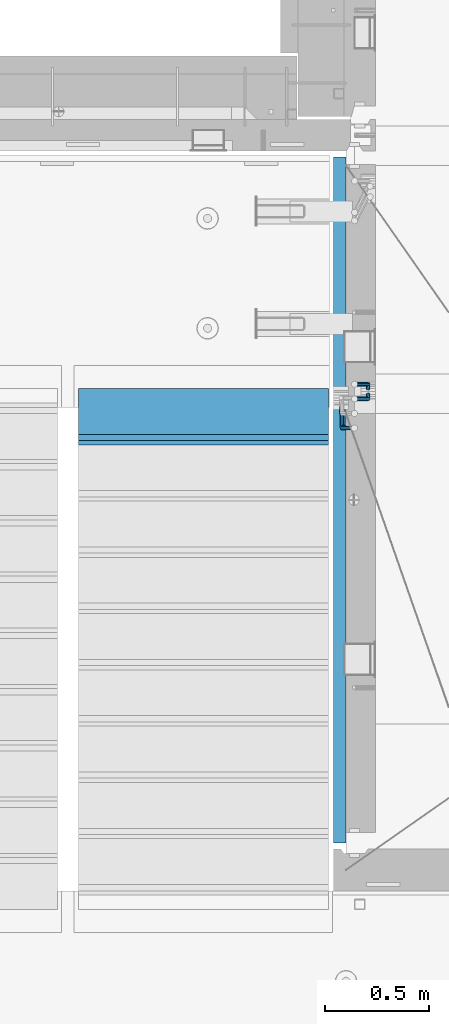
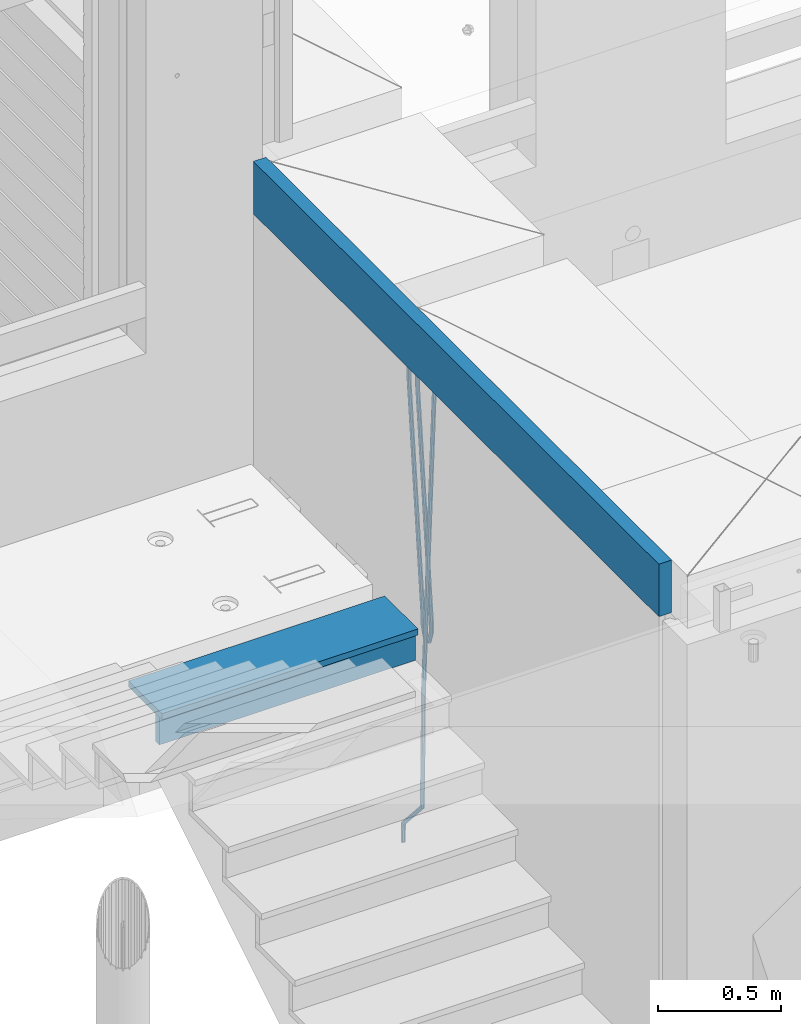
# One storey, part 104 of 325: 6 beams, 2 elements without a shape of their own.
"""IFC2X3 building model written with IfcOpenShell, lengths in millimetres."""

from ifc_helpers import new_model, si_unit, frame, origin_with_axes, place, context, subcontext, project, spatial, faceted_brep, material, type_object, element, aggregate, save


model = new_model("IFC2X3")

# Units and contexts
model_context = context("Model", 3, precision=1e-05, world=origin_with_axes())
body_context = subcontext(model_context, "Body", "Model", "MODEL_VIEW")
ifc_project = project(units=[si_unit("LENGTHUNIT", "METRE", prefix="MILLI"), si_unit("AREAUNIT", "SQUARE_METRE"), si_unit("VOLUMEUNIT", "CUBIC_METRE"), si_unit("MASSUNIT", "GRAM", prefix="KILO"), si_unit("TIMEUNIT", "SECOND"), si_unit("PLANEANGLEUNIT", "RADIAN"), si_unit("SOLIDANGLEUNIT", "STERADIAN"), si_unit("THERMODYNAMICTEMPERATUREUNIT", "DEGREE_CELSIUS"), si_unit("LUMINOUSINTENSITYUNIT", "LUMEN")], contexts=[model_context])

# Site, building, storey
site_placement = place(None, origin_with_axes())
site = spatial("IfcSite", under=ifc_project, at=site_placement, CompositionType="ELEMENT")
building_placement = place(site_placement, origin_with_axes())
building = spatial("IfcBuilding", under=site, at=building_placement, CompositionType="ELEMENT")
storey_placement = place(building_placement, origin_with_axes())
storey = spatial("IfcBuildingStorey", under=building, at=storey_placement, Name="1", CompositionType="ELEMENT", Elevation=0.0)

# Assembly, beams
assembly_1_placement = place(storey_placement, origin_with_axes())
assembly_1 = element("IfcElementAssembly", 1, at=assembly_1_placement, inside=storey, AssemblyPlace="NOTDEFINED", PredefinedType="REINFORCEMENT_UNIT")
ifc_material_1 = material()
beam_type_1 = type_object("IfcBeamType", Name="D20", PredefinedType="NOTDEFINED")
beam_1_placement = place(assembly_1_placement, frame((22244.9999977209, 19244.9999999961, 82050.0), z_axis=(0.999839490204639, 0.000205763000043867, -0.0179151190036643), x_axis=(0.0179151190067552, -2.89999975377855e-08, 0.999839511377188)))
beam_1 = element("IfcBeam", 2, at=beam_1_placement, type_object=beam_type_1, material=ifc_material_1, Name="JM20", ObjectType="D20", context=body_context, shape_type="Brep", body=[
    faceted_brep([(0.0, -10.0, 0.0), (-4.19531716033816e-08, -7.07106781186667, -7.07106781187031), (86.7315929719771, -7.07106781168841, -7.07106781093171), (86.731592974611, -9.99999999982174, 9.31322574615479e-10), (0.0, 0.0, -10.0), (86.7315929708711, 1.78260961547494e-10, -9.99999999906868), (4.196772351861e-08, 7.07106781186303, -7.07106781186667), (86.7315929719334, 7.07106781204129, -7.07106781093171), (0.0, 10.0, 0.0), (86.7315929745673, 10.0000000001783, 9.27684595808387e-10), (4.196772351861e-08, 7.07106781185939, 7.07106781185939), (86.7315929772012, 7.07106781204129, 7.07106781279799), (0.0, 0.0, 10.0), (86.7315929782926, 1.74622982740402e-10, 10.0000000009313), (-4.19531716033816e-08, -7.07106781187031, 7.07106781185939), (86.7315929772303, -7.07106781168841, 7.07106781279799), (93.6677956489439, -7.07106781167022, -7.07106781085895), (94.7376134546503, -9.99999999980355, 1.01863406598568e-09), (91.026200105669, 1.81898940354586e-10, -9.99999999902138), (88.3602376677445, 7.07106781204493, -7.07106781091352), (87.2315929745673, 10.0000000001783, 9.3496055342257e-10), (88.3014107802737, 7.07106781204129, 7.07106781281254), (90.9430063235777, 1.89174897968769e-10, 10.000000000975), (93.6089687614876, -7.07106781167386, 7.07106781287075), (98.8911095756193, -2.50758877894623, -7.02048799755357), (100.766554680595, -4.73266449970106, 0.0583810835851182), (94.2602580335224, 2.82551570757641, -9.96868309015917), (89.5866900823166, 8.14258868119578, -7.05919149349938), (87.6081184431823, 10.3289609061103, 0.00364607471055933), (89.4835635481722, 8.10388518535547, 7.08251515584925), (94.1144150902546, 2.7707806988401, 10.0307102484549), (98.7879830414458, -2.54629227479018, 7.12121865179506), (258.451659159182, 136.896481644191, -5.47538790942781), (260.327104264172, 134.671405923429, 1.60348117171452), (253.82080761707, 142.229586130707, -8.42358300202977), (249.147239665865, 147.546659104333, -5.51409140536998), (247.16866802673, 149.733031329244, 1.54874616283632), (249.044113131706, 147.507955608489, 8.62761524397865), (253.674964673817, 142.174851121974, 11.5758103365806), (258.348532625008, 136.857778148344, 8.66631873992083), (259.609028572653, 137.907646419204, -5.46418055530739), (260.703629732772, 135.000366829368, 1.60712724548284), (256.957140256956, 144.969721692669, -8.39321241324069), (254.301404995116, 152.04972473306, -5.46418119056762), (253.197516485467, 155.000285780967, 1.60712634709125), (254.2921176456, 152.093006191128, 8.67843414788877), (256.944005961297, 145.03093091767, 11.6074660058221), (259.599741223123, 137.950927877275, 8.67843478314535), (261.145884681828, 137.907643836123, -5.47671314841864), (261.203613108824, 135.000365989017, 1.60305003345638), (261.121836439444, 144.969714692827, -8.42717424114744), (261.145555515963, 152.049713229706, -5.51999315186185), (261.203147597975, 155.000272325447, 1.54184286560849), (261.260876025, 152.092994478338, 8.62160604748351), (261.284924267369, 145.030923621638, 11.5720671402123), (261.261205190865, 137.950925084755, 8.66488605092309), (839.157665647057, 137.906672338933, -10.1902230354935), (839.215394074068, 134.999394491828, -3.11045985361488), (839.133617404688, 144.968743195634, -13.140684128226), (839.157336481163, 152.048741732513, -10.2335030389368), (839.214928563219, 154.999300828251, -3.17166702147006), (839.272656990215, 152.092022981145, 3.9080961604086), (839.296705232598, 145.029952124449, 6.85855725313741), (839.272986156095, 137.949953587562, 3.95137616384818), (839.868781161887, 137.906671143719, -10.1960219657631), (839.838848779618, 134.999393443952, -3.11554393670303), (839.881250229548, 144.968741939047, -13.1467808460184), (839.868951771874, 152.048740536462, -10.2393060447248), (839.83909005858, 154.999299779189, -3.17675686821167), (839.809157676311, 152.092022079421, 3.90372116084836), (839.796688608665, 145.029951284097, 6.85448004110731), (839.808987066324, 137.949952686675, 3.9470052398101), (840.579822222964, 137.906673584588, -10.1842104245625), (840.462238209511, 134.999395583931, -3.10518843076352), (840.628804777298, 144.968744505262, -13.1343627568021), (840.580492556488, 152.048742979052, -10.2274862023114), (840.463186204273, 154.999301921594, -3.16638962257639), (840.345602190806, 152.092023920934, 3.91263237122257), (840.296619636472, 145.02995300027, 6.8627847034586), (840.344931857282, 137.949954526477, 3.9559081489715), (2234.26962238546, 137.911457860533, 12.9672296118515), (2234.15203837199, 135.004179859876, 20.0462516056541), (2234.31860493978, 144.973528781204, 10.0170772796155), (2234.27029271898, 152.053527254993, 12.9239538341062), (2234.15298636674, 155.004086197539, 19.9850504138449), (2234.03540235329, 152.096808196879, 27.0640724076402), (2233.98641979897, 145.034737276212, 30.0142247398726), (2234.03473201978, 137.954738802422, 27.1073481853855), (2234.80822680684, 137.911459709463, 12.9761767017735), (2234.65218745513, 135.004181576795, 20.0545598902536), (2234.91137536684, 144.973530816071, 10.0269241544374), (2234.90121010756, 152.053529420817, 12.9344343916055), (2234.78368570004, 155.004088362613, 19.9955273490887), (2234.62764634831, 152.096810229945, 27.0739105375687), (2234.52449778831, 145.03473912333, 30.0231630849084), (2234.5346630476, 137.954740518591, 27.1156528477368), (2235.34672799108, 137.904437526307, 12.9880904207748), (2235.15224067199, 134.997660764246, 20.0656229922242), (2235.50403217443, 144.965802430743, 10.0400360042804), (2235.53200656486, 152.045303685409, 12.9483900373125), (2235.41426414385, 154.995865470151, 20.0094781715015), (2235.21977682479, 152.089088708097, 27.0870107429473), (2235.06247264144, 145.027723803654, 30.0350651594381), (2235.03449825099, 137.948222548996, 27.1267111264096), (2257.18426469299, 137.619670868506, 13.471220789932), (2256.98977737389, 134.712894106447, 20.5487533613814), (2257.34156887633, 144.681035772945, 10.5231663734412), (2257.36954326676, 151.760537027607, 13.431520406466), (2257.25180084576, 154.711098812357, 20.4926085406587), (2257.05731352669, 151.804322050295, 27.5701411121045), (2256.90000934334, 144.742957145856, 30.5181955285952), (2256.87203495289, 137.663455891194, 27.6098414955668), (2257.81978538656, 137.611383527939, 13.4852809539261), (2257.64977173437, 134.704287623455, 20.5633549770937), (2257.92004271412, 144.673492336904, 10.5359644413984), (2257.89181433429, 151.75372648902, 13.443075052819), (2257.75163604916, 154.704580842757, 20.5036668193279), (2257.58162239699, 151.797484938277, 27.5817408424919), (2257.48136506943, 144.735376129309, 30.5310573550196), (2257.50959344923, 137.655141977193, 27.6239467436062), (2258.45536166341, 137.613263996915, 13.4991438851757), (2258.30982363551, 134.706257484584, 20.5777578442503), (2258.49856749365, 144.67519573247, 10.5485681479549), (2258.41413173683, 151.755268857134, 13.4544378826395), (2258.25151571419, 154.706072557059, 20.5145340091476), (2258.1059776863, 151.799066044725, 27.5931479682222), (2258.06277185606, 144.737134309165, 30.5437237054466), (2258.14720761286, 137.657061184509, 27.6378539707584), (2358.46082715187, 137.911709587963, 15.6778446678582), (2358.31528912397, 135.004703075636, 22.7564586269327), (2358.50403298211, 144.973641323526, 12.7272689306337), (2358.41959722531, 152.053714448179, 15.6331386653219), (2358.25698120265, 155.004518148104, 22.69323479183), (2358.11144317476, 152.097511635777, 29.7718487509119), (2358.06823734453, 145.035579900217, 32.722424488129), (2358.15267310133, 137.955506775557, 29.8165547534445)], [[[0, 1, 2, 3]], [[1, 4, 5, 2]], [[4, 6, 7, 5]], [[6, 8, 9, 7]], [[8, 10, 11, 9]], [[10, 12, 13, 11]], [[12, 14, 15, 13]], [[14, 0, 3, 15]], [[14, 12, 10, 8, 6, 4, 1, 0]], [[3, 2, 16, 17]], [[2, 5, 18, 16]], [[5, 7, 19, 18]], [[7, 9, 20, 19]], [[9, 11, 21, 20]], [[11, 13, 22, 21]], [[13, 15, 23, 22]], [[15, 3, 17, 23]], [[17, 16, 24, 25]], [[16, 18, 26, 24]], [[18, 19, 27, 26]], [[19, 20, 28, 27]], [[20, 21, 29, 28]], [[21, 22, 30, 29]], [[22, 23, 31, 30]], [[23, 17, 25, 31]], [[25, 24, 32, 33]], [[24, 26, 34, 32]], [[26, 27, 35, 34]], [[27, 28, 36, 35]], [[28, 29, 37, 36]], [[29, 30, 38, 37]], [[30, 31, 39, 38]], [[31, 25, 33, 39]], [[33, 32, 40, 41]], [[32, 34, 42, 40]], [[34, 35, 43, 42]], [[35, 36, 44, 43]], [[36, 37, 45, 44]], [[37, 38, 46, 45]], [[38, 39, 47, 46]], [[39, 33, 41, 47]], [[41, 40, 48, 49]], [[40, 42, 50, 48]], [[42, 43, 51, 50]], [[43, 44, 52, 51]], [[44, 45, 53, 52]], [[45, 46, 54, 53]], [[46, 47, 55, 54]], [[47, 41, 49, 55]], [[49, 48, 56, 57]], [[48, 50, 58, 56]], [[50, 51, 59, 58]], [[51, 52, 60, 59]], [[52, 53, 61, 60]], [[53, 54, 62, 61]], [[54, 55, 63, 62]], [[55, 49, 57, 63]], [[57, 56, 64, 65]], [[56, 58, 66, 64]], [[58, 59, 67, 66]], [[59, 60, 68, 67]], [[60, 61, 69, 68]], [[61, 62, 70, 69]], [[62, 63, 71, 70]], [[63, 57, 65, 71]], [[65, 64, 72, 73]], [[64, 66, 74, 72]], [[66, 67, 75, 74]], [[67, 68, 76, 75]], [[68, 69, 77, 76]], [[69, 70, 78, 77]], [[70, 71, 79, 78]], [[71, 65, 73, 79]], [[73, 72, 80, 81]], [[72, 74, 82, 80]], [[74, 75, 83, 82]], [[75, 76, 84, 83]], [[76, 77, 85, 84]], [[77, 78, 86, 85]], [[78, 79, 87, 86]], [[79, 73, 81, 87]], [[81, 80, 88, 89]], [[80, 82, 90, 88]], [[82, 83, 91, 90]], [[83, 84, 92, 91]], [[84, 85, 93, 92]], [[85, 86, 94, 93]], [[86, 87, 95, 94]], [[87, 81, 89, 95]], [[89, 88, 96, 97]], [[88, 90, 98, 96]], [[90, 91, 99, 98]], [[91, 92, 100, 99]], [[92, 93, 101, 100]], [[93, 94, 102, 101]], [[94, 95, 103, 102]], [[95, 89, 97, 103]], [[97, 96, 104, 105]], [[96, 98, 106, 104]], [[98, 99, 107, 106]], [[99, 100, 108, 107]], [[100, 101, 109, 108]], [[101, 102, 110, 109]], [[102, 103, 111, 110]], [[103, 97, 105, 111]], [[105, 104, 112, 113]], [[104, 106, 114, 112]], [[106, 107, 115, 114]], [[107, 108, 116, 115]], [[108, 109, 117, 116]], [[109, 110, 118, 117]], [[110, 111, 119, 118]], [[111, 105, 113, 119]], [[113, 112, 120, 121]], [[112, 114, 122, 120]], [[114, 115, 123, 122]], [[115, 116, 124, 123]], [[116, 117, 125, 124]], [[117, 118, 126, 125]], [[118, 119, 127, 126]], [[119, 113, 121, 127]], [[121, 120, 128, 129]], [[120, 122, 130, 128]], [[122, 123, 131, 130]], [[123, 124, 132, 131]], [[124, 125, 133, 132]], [[125, 126, 134, 133]], [[126, 127, 135, 134]], [[127, 121, 129, 135]], [[130, 131, 132, 133, 134, 135, 129, 128]]]),
])
beam_2_placement = place(assembly_1_placement, frame((22375.0998642727, 19290.4651594444, 82985.0), z_axis=(-1.0, 3.00000001838171e-08, 0.0), x_axis=(0.0, 0.316227766016838, 0.948683298050514)))
beam_2 = element("IfcBeam", 3, at=beam_2_placement, type_object=beam_type_1, material=ifc_material_1, Name="JM20", ObjectType="D20", context=body_context, shape_type="Brep", body=[
    faceted_brep([(0.0, -10.0, 0.0), (-4.19531716033816e-08, -7.07106781186667, -7.07106781187031), (61.1227766014781, -7.07106781179846, -7.07106781186667), (61.1227766014781, -9.99999999993179, 0.0), (0.0, 0.0, -10.0), (61.1227766014781, 6.45741238258779e-11, -10.0), (4.196772351861e-08, 7.07106781186303, -7.07106781186667), (61.1227766014636, 7.07106781193124, -7.07106781186667), (0.0, 10.0, 0.0), (61.1227766014636, 10.0000000000682, 0.0), (4.196772351861e-08, 7.07106781185939, 7.07106781185939), (61.1227766014636, 7.07106781193124, 7.07106781186667), (0.0, 0.0, 10.0), (61.1227766014781, 6.45741238258779e-11, 10.0), (-4.19531716033816e-08, -7.07106781187031, 7.07106781185939), (61.1227766014781, -7.07106781179846, 7.07106781186667), (62.0980768637673, -7.0710678118021, -7.07106781186667), (61.6227766014781, -9.99999999993179, 0.0), (63.2455532031745, 6.45741238258779e-11, -10.0), (64.3930295425671, 7.07106781193852, -7.07106781186667), (64.8683298048418, 10.0000000000719, 0.0), (64.3930295425671, 7.07106781193852, 7.07106781186667), (63.2455532031745, 6.45741238258779e-11, 10.0), (62.0980768637673, -7.0710678118021, 7.07106781186667), (63.0233279331733, -7.37948483493619, -7.07106781186667), (62.0971182505018, -10.1581138829397, 0.0), (65.2593959106744, -0.671280902436592, -10.0), (67.4954638881754, 6.03692303006665, -7.07106781186667), (68.4216735708469, 8.81555207807014, 0.0), (67.4954638881754, 6.03692303006665, 7.07106781186667), (65.2593959106744, -0.671280902436592, 10.0), (63.0233279331733, -7.37948483493619, 7.07106781186667), (107.709464777348, -22.2748637829909, -7.07106781186667), (106.783255094677, -25.0534928309944, 0.0), (109.945532754849, -15.5666598504913, -10.0), (112.18160073235, -8.85845591798807, -7.07106781186667), (113.107810415022, -6.07982686998457, 0.0), (112.18160073235, -8.85845591798807, 7.07106781186667), (109.945532754849, -15.5666598504913, 10.0), (107.709464777348, -22.2748637829909, 7.07106781186667), (108.62738737154, -22.5808379810596, -7.07106781186667), (107.517440445372, -25.2982212812285, 0.0), (110.939561807201, -15.8980028679443, -10.0), (113.099523326542, -9.16443011605679, -7.07106781186667), (113.841995765717, -6.32455532021868, 0.0), (112.732048839549, -9.04193862038755, 7.07106781186667), (110.419874403873, -15.7247737334992, 10.0), (108.259912884547, -22.4583464853904, 7.07106781186667), (109.543933731853, -22.8863534344937, -7.01810390034007), (108.250525037933, -25.5425828120797, 0.0423623170463543), (111.932100519902, -16.2288491055087, -9.94264476425815), (114.016069686855, -9.46994556949085, -7.01810390034007), (114.575080358278, -6.56891685106984, 0.0423623170463543), (113.281671664372, -9.22514622866311, 7.10282853442914), (110.893504876323, -15.8826505576517, 10.0273693983472), (108.80953570937, -22.6415540936659, 7.10282853442914), (1234.64045484473, -397.918527138788, 57.997169939692), (1233.34704615081, -400.574756516381, 65.0576361570747), (1237.02862163277, -391.261022809803, 55.0726290757739), (1239.11259079973, -384.502119273789, 57.997169939692), (1239.67160147114, -381.601090555371, 65.0576361570747), (1238.37819277724, -384.257319932957, 72.1181023744612), (1235.9900259892, -390.914824261946, 75.0426432383792), (1233.90605682223, -397.673727797956, 72.1181023744612), (1235.19007766954, -398.10173474706, 58.0289306622544), (1234.08013074337, -400.819118047232, 65.0999984741211), (1237.50225210523, -391.418899633955, 55.0999984741211), (1239.66221362454, -384.685326882061, 58.0289306622544), (1240.4046860637, -381.845452086222, 65.0999984741211), (1239.29473913755, -384.562835386395, 72.1710662859878), (1236.98256470189, -391.24567049951, 75.0999984741211), (1234.82260318255, -397.979243251394, 72.1710662859878), (1235.74052577675, -398.285217449463, 58.0289306622581), (1234.81431609408, -401.063846497466, 65.0999984741211), (1237.97659375425, -391.577013516963, 55.0999984741211), (1240.21266173176, -384.86880958446, 58.0289306622544), (1241.13887141441, -382.090180536457, 65.0999984741211), (1240.21266173176, -384.86880958446, 72.1710662859841), (1237.97659375425, -391.57701351696, 75.0999984741211), (1235.74052577675, -398.285217449459, 72.1710662859878), (1353.59175268197, -437.568959751207, 58.0289306622581), (1352.6655429993, -440.347588799211, 65.0999984741211), (1355.82782065947, -430.860755818708, 55.0999984741211), (1358.06388863697, -424.152551886204, 58.0289306622544), (1358.99009831963, -421.373922838201, 65.0999984741211), (1358.06388863697, -424.152551886204, 72.1710662859841), (1355.82782065947, -430.860755818704, 75.0999984741211), (1353.59175268197, -437.568959751204, 72.1710662859878)], [[[0, 1, 2, 3]], [[1, 4, 5, 2]], [[4, 6, 7, 5]], [[6, 8, 9, 7]], [[8, 10, 11, 9]], [[10, 12, 13, 11]], [[12, 14, 15, 13]], [[14, 0, 3, 15]], [[14, 12, 10, 8, 6, 4, 1, 0]], [[3, 2, 16, 17]], [[2, 5, 18, 16]], [[5, 7, 19, 18]], [[7, 9, 20, 19]], [[9, 11, 21, 20]], [[11, 13, 22, 21]], [[13, 15, 23, 22]], [[15, 3, 17, 23]], [[17, 16, 24, 25]], [[16, 18, 26, 24]], [[18, 19, 27, 26]], [[19, 20, 28, 27]], [[20, 21, 29, 28]], [[21, 22, 30, 29]], [[22, 23, 31, 30]], [[23, 17, 25, 31]], [[25, 24, 32, 33]], [[24, 26, 34, 32]], [[26, 27, 35, 34]], [[27, 28, 36, 35]], [[28, 29, 37, 36]], [[29, 30, 38, 37]], [[30, 31, 39, 38]], [[31, 25, 33, 39]], [[33, 32, 40, 41]], [[32, 34, 42, 40]], [[34, 35, 43, 42]], [[35, 36, 44, 43]], [[36, 37, 45, 44]], [[37, 38, 46, 45]], [[38, 39, 47, 46]], [[39, 33, 41, 47]], [[41, 40, 48, 49]], [[40, 42, 50, 48]], [[42, 43, 51, 50]], [[43, 44, 52, 51]], [[44, 45, 53, 52]], [[45, 46, 54, 53]], [[46, 47, 55, 54]], [[47, 41, 49, 55]], [[49, 48, 56, 57]], [[48, 50, 58, 56]], [[50, 51, 59, 58]], [[51, 52, 60, 59]], [[52, 53, 61, 60]], [[53, 54, 62, 61]], [[54, 55, 63, 62]], [[55, 49, 57, 63]], [[57, 56, 64, 65]], [[56, 58, 66, 64]], [[58, 59, 67, 66]], [[59, 60, 68, 67]], [[60, 61, 69, 68]], [[61, 62, 70, 69]], [[62, 63, 71, 70]], [[63, 57, 65, 71]], [[65, 64, 72, 73]], [[64, 66, 74, 72]], [[66, 67, 75, 74]], [[67, 68, 76, 75]], [[68, 69, 77, 76]], [[69, 70, 78, 77]], [[70, 71, 79, 78]], [[71, 65, 73, 79]], [[73, 72, 80, 81]], [[72, 74, 82, 80]], [[74, 75, 83, 82]], [[75, 76, 84, 83]], [[76, 77, 85, 84]], [[77, 78, 86, 85]], [[78, 79, 87, 86]], [[79, 73, 81, 87]], [[82, 83, 84, 85, 86, 87, 81, 80]]]),
])
beam_3_placement = place(assembly_1_placement, frame((22375.0998642727, 19260.4651594444, 82985.0), z_axis=(1.0, 0.0, 0.0), x_axis=(0.0, -0.316227766016872, 0.948683298050502)))
beam_3 = element("IfcBeam", 4, at=beam_3_placement, type_object=beam_type_1, material=ifc_material_1, Name="JM20", ObjectType="D20", context=body_context, shape_type="Brep", body=[
    faceted_brep([(0.0, -10.0, 0.0), (-4.19531716033816e-08, -7.07106781186667, -7.07106781187031), (61.1227766014781, -7.07106781179846, -7.07106781186667), (61.1227766014781, -9.99999999993179, 0.0), (0.0, 0.0, -10.0), (61.1227766014781, 6.45741238258779e-11, -10.0), (4.196772351861e-08, 7.07106781186303, -7.07106781186667), (61.1227766014636, 7.07106781193124, -7.07106781186667), (0.0, 10.0, 0.0), (61.1227766014636, 10.0000000000682, 0.0), (4.196772351861e-08, 7.07106781185939, 7.07106781185939), (61.1227766014636, 7.07106781193124, 7.07106781186667), (0.0, 0.0, 10.0), (61.1227766014781, 6.45741238258779e-11, 10.0), (-4.19531716033816e-08, -7.07106781187031, 7.07106781185939), (61.1227766014781, -7.07106781179846, 7.07106781186667), (62.0980768637673, -7.0710678118021, -7.07106781186667), (61.6227766014781, -9.99999999993179, 0.0), (63.2455532031745, 6.45741238258779e-11, -10.0), (64.3930295425671, 7.07106781193852, -7.07106781186667), (64.8683298048418, 10.0000000000719, 0.0), (64.3930295425671, 7.07106781193852, 7.07106781186667), (63.2455532031745, 6.45741238258779e-11, 10.0), (62.0980768637673, -7.0710678118021, 7.07106781186667), (63.0233279331733, -7.37948483493619, -7.07106781186667), (62.0971182505018, -10.1581138829397, 0.0), (65.2593959106744, -0.671280902436592, -10.0), (67.4954638881754, 6.03692303006665, -7.07106781186667), (68.4216735708469, 8.81555207807014, 0.0), (67.4954638881754, 6.03692303006665, 7.07106781186667), (65.2593959106744, -0.671280902436592, 10.0), (63.0233279331733, -7.37948483493619, 7.07106781186667), (107.709464777348, -22.2748637829909, -7.07106781186667), (106.783255094677, -25.0534928309944, 0.0), (109.945532754849, -15.5666598504913, -10.0), (112.18160073235, -8.85845591798807, -7.07106781186667), (113.107810415022, -6.07982686998457, 0.0), (112.18160073235, -8.85845591798807, 7.07106781186667), (109.945532754849, -15.5666598504913, 10.0), (107.709464777348, -22.2748637829909, 7.07106781186667), (108.259912884547, -22.4583464853931, -7.07106781186667), (107.517440445372, -25.2982212812285, 0.0), (110.419874403873, -15.7247737334983, -10.0), (112.732048839549, -9.04193862038665, -7.07106781186667), (113.841995765717, -6.32455532021868, 0.0), (113.099523326542, -9.16443011605588, 7.07106781186667), (110.939561807216, -15.8980028679434, 10.0), (108.62738737154, -22.5808379810551, 7.07106781186667), (108.80953570937, -22.641554093665, -7.10282853442914), (108.250525037933, -25.5425828120788, -0.0423623170463543), (110.893504876323, -15.8826505576508, -10.0273693983472), (113.281671664372, -9.22514622866584, -7.10282853442914), (114.575080358263, -6.56891685107257, -0.0423623170463543), (114.016069686855, -9.46994556949358, 7.01810390034007), (111.932100519902, -16.2288491055078, 9.94264476425815), (109.543933731853, -22.8863534344928, 7.01810390034007), (1233.90605682225, -397.673727797956, -72.1181023744612), (1233.34704615083, -400.574756516377, -65.0576361570747), (1235.9900259892, -390.914824261941, -75.0426432383792), (1238.37819277724, -384.257319932956, -72.1181023744612), (1239.67160147116, -381.60109055537, -65.0576361570747), (1239.11259079972, -384.502119273791, -57.997169939692), (1237.02862163277, -391.261022809806, -55.0726290757739), (1234.64045484473, -397.918527138783, -57.997169939692), (1234.82260318255, -397.979243251393, -72.1710662859878), (1234.08013074339, -400.819118047235, -65.0999984741211), (1236.98256470189, -391.245670499506, -75.0999984741211), (1239.29473913753, -384.562835386394, -72.1710662859878), (1240.40468606372, -381.845452086229, -65.0999984741211), (1239.66221362454, -384.685326882056, -58.0289306622544), (1237.50225210523, -391.418899633951, -55.0999984741211), (1235.19007766955, -398.101734747062, -58.0289306622544), (1235.74052577675, -398.285217449462, -72.1710662859878), (1234.81431609408, -401.063846497462, -65.0999984741211), (1237.97659375424, -391.577013516959, -75.0999984741211), (1240.21266173174, -384.868809584455, -72.1710662859878), (1241.13887141441, -382.090180536456, -65.0999984741211), (1240.21266173174, -384.868809584455, -58.0289306622544), (1237.97659375424, -391.577013516959, -55.0999984741211), (1235.74052577675, -398.285217449462, -58.0289306622544), (1353.59175268198, -437.568959751203, -72.1710662859878), (1352.66554299931, -440.34758879921, -65.0999984741211), (1355.82782065948, -430.8607558187, -75.0999984741211), (1358.06388863699, -424.152551886204, -72.1710662859878), (1358.99009831964, -421.373922838196, -65.0999984741211), (1358.06388863699, -424.152551886204, -58.0289306622544), (1355.82782065948, -430.8607558187, -55.0999984741211), (1353.59175268198, -437.568959751203, -58.0289306622544)], [[[0, 1, 2, 3]], [[1, 4, 5, 2]], [[4, 6, 7, 5]], [[6, 8, 9, 7]], [[8, 10, 11, 9]], [[10, 12, 13, 11]], [[12, 14, 15, 13]], [[14, 0, 3, 15]], [[14, 12, 10, 8, 6, 4, 1, 0]], [[3, 2, 16, 17]], [[2, 5, 18, 16]], [[5, 7, 19, 18]], [[7, 9, 20, 19]], [[9, 11, 21, 20]], [[11, 13, 22, 21]], [[13, 15, 23, 22]], [[15, 3, 17, 23]], [[17, 16, 24, 25]], [[16, 18, 26, 24]], [[18, 19, 27, 26]], [[19, 20, 28, 27]], [[20, 21, 29, 28]], [[21, 22, 30, 29]], [[22, 23, 31, 30]], [[23, 17, 25, 31]], [[25, 24, 32, 33]], [[24, 26, 34, 32]], [[26, 27, 35, 34]], [[27, 28, 36, 35]], [[28, 29, 37, 36]], [[29, 30, 38, 37]], [[30, 31, 39, 38]], [[31, 25, 33, 39]], [[33, 32, 40, 41]], [[32, 34, 42, 40]], [[34, 35, 43, 42]], [[35, 36, 44, 43]], [[36, 37, 45, 44]], [[37, 38, 46, 45]], [[38, 39, 47, 46]], [[39, 33, 41, 47]], [[41, 40, 48, 49]], [[40, 42, 50, 48]], [[42, 43, 51, 50]], [[43, 44, 52, 51]], [[44, 45, 53, 52]], [[45, 46, 54, 53]], [[46, 47, 55, 54]], [[47, 41, 49, 55]], [[49, 48, 56, 57]], [[48, 50, 58, 56]], [[50, 51, 59, 58]], [[51, 52, 60, 59]], [[52, 53, 61, 60]], [[53, 54, 62, 61]], [[54, 55, 63, 62]], [[55, 49, 57, 63]], [[57, 56, 64, 65]], [[56, 58, 66, 64]], [[58, 59, 67, 66]], [[59, 60, 68, 67]], [[60, 61, 69, 68]], [[61, 62, 70, 69]], [[62, 63, 71, 70]], [[63, 57, 65, 71]], [[65, 64, 72, 73]], [[64, 66, 74, 72]], [[66, 67, 75, 74]], [[67, 68, 76, 75]], [[68, 69, 77, 76]], [[69, 70, 78, 77]], [[70, 71, 79, 78]], [[71, 65, 73, 79]], [[73, 72, 80, 81]], [[72, 74, 82, 80]], [[74, 75, 83, 82]], [[75, 76, 84, 83]], [[76, 77, 85, 84]], [[77, 78, 86, 85]], [[78, 79, 87, 86]], [[79, 73, 81, 87]], [[82, 83, 84, 85, 86, 87, 81, 80]]]),
])
ifc_material_2 = material(Name="CONCRETE/C25/30")
beam_type_2 = type_object("IfcBeamType", Name="260X60", PredefinedType="NOTDEFINED")
beam_4_placement = place(assembly_1_placement, frame((22240.0000000001, 20400.0, 84600.0), z_axis=(0.0, 0.0, 1.0), x_axis=(0.0, -1.0, 0.0)))
beam_4 = element("IfcBeam", 5, at=beam_4_placement, type_object=beam_type_2, material=ifc_material_2, ObjectType="260X60", context=body_context, shape_type="Brep", body=[
    faceted_brep([(0.0, 30.0, -130.0), (0.0, 30.0, 130.0), (3290.0, 30.0, 130.0), (3290.0, 30.0, -130.0), (0.0, -30.0, 130.0), (3290.0, -30.0, 130.0), (0.0, -30.0, -130.0), (3290.0, -30.0, -130.0)], [[[0, 1, 2, 3]], [[1, 4, 5, 2]], [[4, 6, 7, 5]], [[6, 0, 3, 7]], [[5, 7, 3, 2]], [[6, 4, 1, 0]]]),
])
aggregate(assembly_1, [beam_1, beam_2, beam_3, beam_4])

assembly_2_placement = place(storey_placement, origin_with_axes())
assembly_2 = element("IfcElementAssembly", 6, at=assembly_2_placement, inside=storey, Name="E9", AssemblyPlace="NOTDEFINED", PredefinedType="NOTDEFINED")
ifc_material_3 = material(Name="Undefined/C32/40")
beam_type_3 = type_object("IfcBeamType", PredefinedType="NOTDEFINED")
beam_5_placement = place(assembly_2_placement, frame((20985.002175553, 19055.001025346, 83161.803607297), z_axis=(0.0, -1.0, 0.0), x_axis=(1.0, 0.0, 0.0)))
beam_5 = element("IfcBeam", 7, at=beam_5_placement, type_object=beam_type_3, material=ifc_material_3, Name="E9", context=body_context, shape_type="Brep", body=[
    faceted_brep([(0.0, 68.5, -15.0), (0.0, 68.5, 15.0), (1200.0, 68.5, 15.0), (1200.0, 68.5, -15.0), (0.0, -68.5, 15.0), (1200.0, -68.5, 15.0), (0.0, -68.5, -15.0), (1200.0, -68.5, -15.0)], [[[0, 1, 2, 3]], [[1, 4, 5, 2]], [[4, 6, 7, 5]], [[6, 0, 3, 7]], [[5, 7, 3, 2]], [[6, 4, 1, 0]]]),
])
beam_type_4 = type_object("IfcBeamType", PredefinedType="NOTDEFINED")
beam_6_placement = place(assembly_2_placement, frame((20985.002175553, 19155.001025346, 83245.003607297), z_axis=(0.0, -1.0, 0.0), x_axis=(1.0, 0.0, 0.0)))
beam_6 = element("IfcBeam", 8, at=beam_6_placement, type_object=beam_type_4, material=ifc_material_3, Name="E9", context=body_context, shape_type="Brep", body=[
    faceted_brep([(0.0, 15.0, -135.0), (0.0, 15.0, 135.0), (1200.0, 15.0, 135.0), (1200.0, 15.0, -135.0), (0.0, -15.0, 135.0), (1200.0, -15.0, 135.0), (0.0, -15.0, -135.0), (1200.0, -15.0, -135.0)], [[[0, 1, 2, 3]], [[1, 4, 5, 2]], [[4, 6, 7, 5]], [[6, 0, 3, 7]], [[5, 7, 3, 2]], [[6, 4, 1, 0]]]),
])
aggregate(assembly_2, [beam_6, beam_5])

save(model, "model.ifc")
